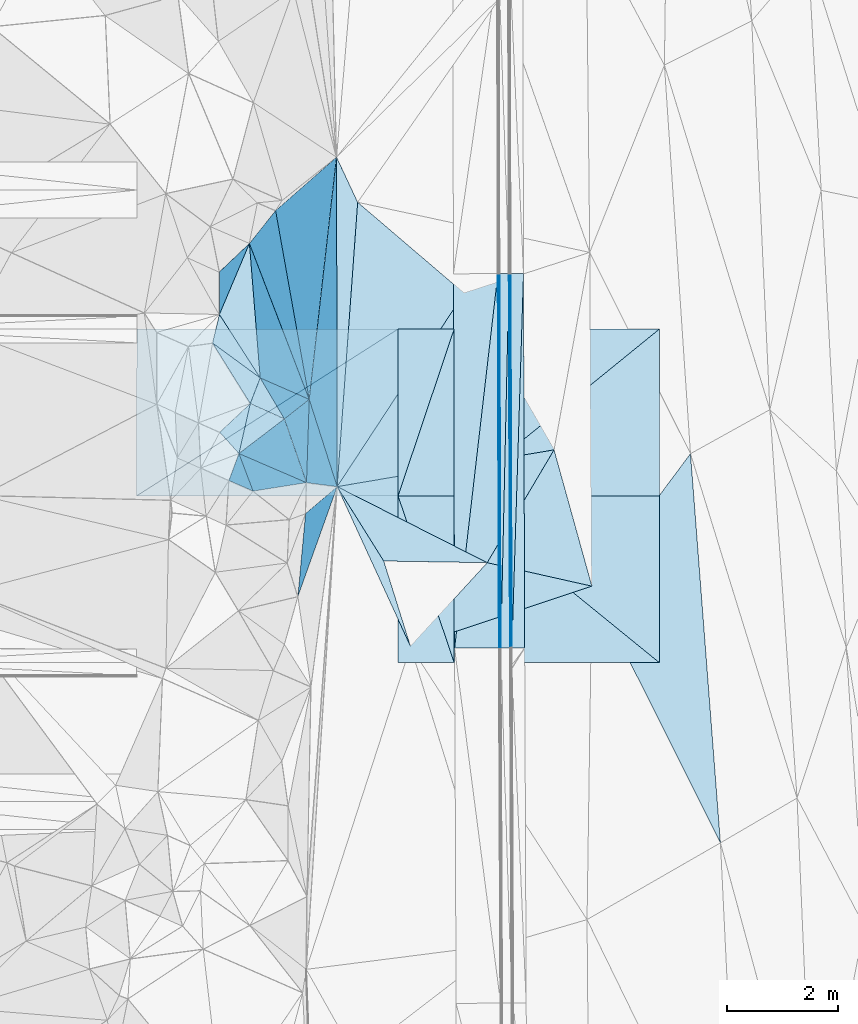
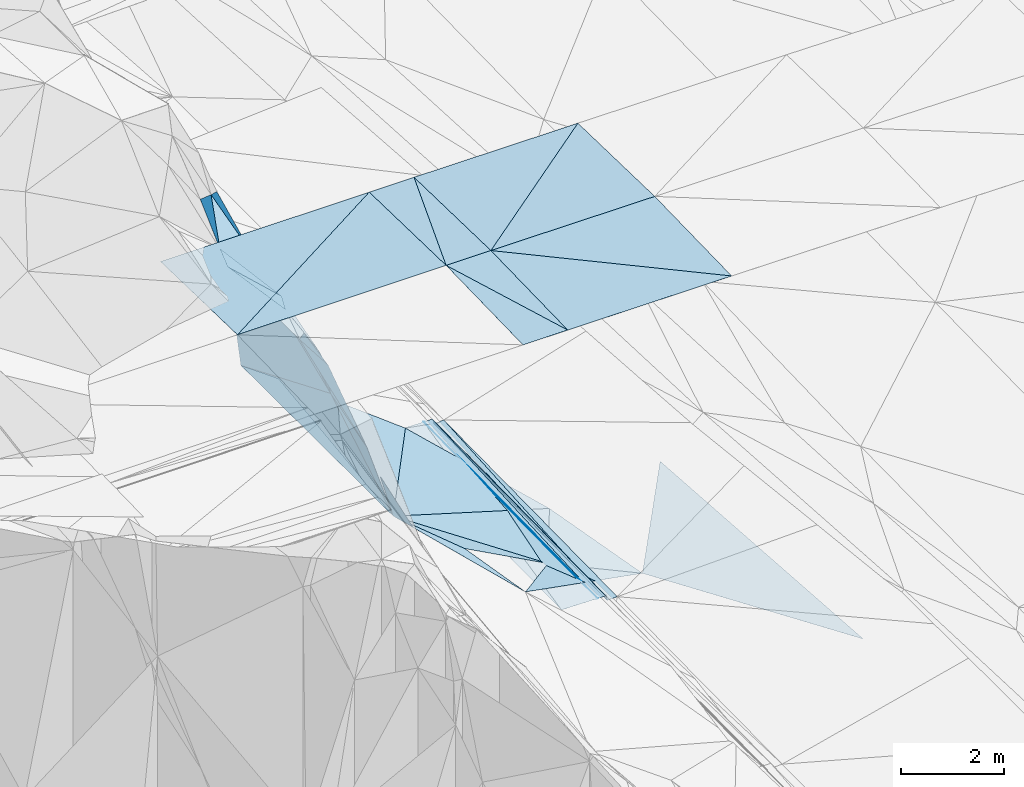
# One storey, part 65 of 275: 47 plates.
"""IFC2X3 building model written with IfcOpenShell, lengths in millimetres."""

from ifc_helpers import new_model, si_unit, frame, origin_with_axes, place, context, subcontext, project, spatial, polyline, outline, extrude, material, type_object, element, save


model = new_model("IFC2X3")

# Units and contexts
model_context = context("Model", 3, precision=1e-05, world=origin_with_axes())
body_context = subcontext(model_context, "Body", "Model", "MODEL_VIEW")
ifc_project = project(units=[si_unit("LENGTHUNIT", "METRE", prefix="MILLI"), si_unit("AREAUNIT", "SQUARE_METRE"), si_unit("VOLUMEUNIT", "CUBIC_METRE"), si_unit("MASSUNIT", "GRAM", prefix="KILO"), si_unit("TIMEUNIT", "SECOND"), si_unit("PLANEANGLEUNIT", "RADIAN"), si_unit("SOLIDANGLEUNIT", "STERADIAN"), si_unit("THERMODYNAMICTEMPERATUREUNIT", "DEGREE_CELSIUS"), si_unit("LUMINOUSINTENSITYUNIT", "LUMEN")], contexts=[model_context])

# Site, building, storey
site_placement = place(None, origin_with_axes())
site = spatial("IfcSite", under=ifc_project, at=site_placement, CompositionType="ELEMENT")
building_placement = place(site_placement, origin_with_axes())
building = spatial("IfcBuilding", under=site, at=building_placement, Name="Undefined", CompositionType="ELEMENT")
storey_placement = place(building_placement, origin_with_axes())
storey = spatial("IfcBuildingStorey", under=building, at=storey_placement, Name="Undefined", CompositionType="ELEMENT", Elevation=0.0)

# Plates
ifc_material = material()
plate_type_1 = type_object("IfcPlateType", PredefinedType="NOTDEFINED")
plate_1_placement = place(storey_placement, frame((-94084.5866878203, 60556.9607628833, 42156.7079027058), z_axis=(-0.970225952350505, 0.00174318954264599, -0.242195298624425), x_axis=(-0.24219982005239, -0.0107861419939103, 0.970166432272049)))
element("IfcPlate", 1, at=plate_1_placement, inside=storey, type_object=plate_type_1, material=ifc_material, Name="00_PR", context=body_context, shape_type="SweptSolid", body=[
    extrude(outline(polyline([(0.0, 0.0), (123.690116882324, -3.49245965480804e-10), (186.194259643555, 6733.92724609375), (0.0, 0.0)])), frame((-8.85201319254618e-08, 2.18876761149539e-07, -0.5000001331573), z_axis=(0.0, 0.0, 1.0), x_axis=(1.0, 0.0, 0.0)), (0.0, 0.0, 1.0), 1.0),
])
plate_2_placement = place(storey_placement, frame((-94084.5866508757, 60556.9607676116, 42156.707743543), z_axis=(-0.970146549983046, 0.00175578360788355, -0.242513069297131), x_axis=(-0.00761512513655447, 0.999260159427567, 0.0376980589679076)))
element("IfcPlate", 2, at=plate_2_placement, inside=storey, type_object=plate_type_1, material=ifc_material, Name="00_PR", context=body_context, shape_type="SweptSolid", body=[
    extrude(outline(polyline([(0.0, 0.0), (6736.5009765625, -1.44500518217683e-08), (6732.044921875, 123.612670898438), (0.0, 0.0)])), frame((-8.85201319254618e-08, 2.18876761149539e-07, -0.5000001331573), z_axis=(0.0, 0.0, 1.0), x_axis=(1.0, 0.0, 0.0)), (0.0, 0.0, 1.0), 1.0),
])
plate_type_2 = type_object("IfcPlateType", PredefinedType="NOTDEFINED")
plate_3_placement = place(storey_placement, frame((-94305.4100903076, 67288.0426014799, 42410.2821987187), z_axis=(-0.0200661071040708, 0.0198232530296892, -0.999602115836601), x_axis=(0.00316902509738513, -0.999797135364924, -0.0198908369865247)))
element("IfcPlate", 3, at=plate_3_placement, inside=storey, type_object=plate_type_2, material=ifc_material, Name="00_PR", context=body_context, shape_type="SweptSolid", body=[
    extrude(outline(polyline([(0.0, 0.0), (6734.4072265625, -2.37050699070096e-08), (6734.412109375, 30.0058002471924), (0.0, 0.0)])), frame((-8.85201319254618e-08, 2.18876761149539e-07, -0.5000001331573), z_axis=(0.0, 0.0, 1.0), x_axis=(1.0, 0.0, 0.0)), (0.0, 0.0, 1.0), 1.0),
])
plate_4_placement = place(storey_placement, frame((-94335.4103191696, 67287.9645285141, 42410.8821981604), z_axis=(-0.0200434799292692, 0.0198233340457199, -0.999602568193798), x_axis=(0.999796679103083, 0.00260181411594454, -0.0199957749975811)))
element("IfcPlate", 4, at=plate_4_placement, inside=storey, type_object=plate_type_2, material=ifc_material, Name="00_PR", context=body_context, shape_type="SweptSolid", body=[
    extrude(outline(polyline([(0.0, 0.0), (30.0063400268555, 1.74622982740402e-10), (6.49809312820435, 6734.43798828125), (0.0, 0.0)])), frame((-8.85201319254618e-08, 2.18876761149539e-07, -0.5000001331573), z_axis=(0.0, 0.0, 1.0), x_axis=(1.0, 0.0, 0.0)), (0.0, 0.0, 1.0), 1.0),
])
plate_type_3 = type_object("IfcPlateType", PredefinedType="NOTDEFINED")
plate_5_placement = place(storey_placement, frame((-94335.4103191696, 67287.9645285141, 42410.8821981604), z_axis=(-0.0200438489268116, 0.0198206888100903, -0.999602613249532), x_axis=(-0.114812645896332, -0.99323490015568, -0.0173922239814446)))
element("IfcPlate", 5, at=plate_5_placement, inside=storey, type_object=plate_type_3, material=ifc_material, Name="00_PR", context=body_context, shape_type="SweptSolid", body=[
    extrude(outline(polyline([(0.0, 0.0), (6781.9384765625, 2.69792508333921e-08), (93.6457214355469, 794.661682128906), (0.0, 0.0)])), frame((-8.85201319254618e-08, 2.18876761149539e-07, -0.5000001331573), z_axis=(0.0, 0.0, 1.0), x_axis=(1.0, 0.0, 0.0)), (0.0, 0.0, 1.0), 1.0),
])
plate_6_placement = place(storey_placement, frame((-95114.0626632694, 60551.9062880618, 42292.9291988022), z_axis=(-0.0200661071040708, 0.0198232530296892, -0.999602115836601), x_axis=(0.114812645896035, 0.993234900155656, 0.0173922239847419)))
element("IfcPlate", 6, at=plate_6_placement, inside=storey, type_object=plate_type_3, material=ifc_material, Name="00_PR", context=body_context, shape_type="SweptSolid", body=[
    extrude(outline(polyline([(0.0, 0.0), (6781.9384765625, 2.69792508333921e-08), (94.5344314575195, 794.556030273438), (0.0, 0.0)])), frame((-8.85201319254618e-08, 2.18876761149539e-07, -0.5000001331573), z_axis=(0.0, 0.0, 1.0), x_axis=(1.0, 0.0, 0.0)), (0.0, 0.0, 1.0), 1.0),
])
plate_type_4 = type_object("IfcPlateType", PredefinedType="NOTDEFINED")
for number, where, z_axis, x_axis, name in (
    (7, (-95122.3312038768, 60292.3543277602, 49117.0561508997), (0.000281023931239556, 0.0249921740341034, -0.999687607336712), (-0.999999959261864, 5.7025981593102e-05, -0.000279686088416769), "00_PR"),
    (8, (-96130.434008878, 63292.4118475478, 49191.7741507655), (0.000281023931239556, 0.0249921740341034, -0.999687607336712), (0.999999959261864, -5.70259785334166e-05, 0.000279686088395133), "00_PR"),
):
    element("IfcPlate", number, at=place(storey_placement, frame(where, z_axis=z_axis, x_axis=x_axis)), inside=storey, type_object=plate_type_4, material=ifc_material, Name=name, context=body_context, shape_type="SweptSolid", body=[
        extrude(outline(polyline([(0.0, 0.0), (1008.27471923828, -2.35013430938125e-09), (1008.2529296875, 3000.9375), (0.0, 0.0)])), frame((-8.85201319254618e-08, 2.18876761149539e-07, -0.5000001331573), z_axis=(0.0, 0.0, 1.0), x_axis=(1.0, 0.0, 0.0)), (0.0, 0.0, 1.0), 1.0),
    ])
for number, where, z_axis, x_axis, name in (
    (9, (-95121.9874384539, 66292.3293787382, 49117.0561508634), (0.000278173513506451, -0.0249922059940395, -0.999687607334935), (-5.7277968073799e-05, -0.999687644772795, 0.0249921909375039), "00_PR"),
    (10, (-96130.4340091923, 63292.3868551628, 49191.7741506891), (0.000278173513506451, -0.0249922059940395, -0.999687607334935), (5.72779774420735e-05, 0.999687644773175, -0.0249921909222736), "00_PR"),
):
    element("IfcPlate", number, at=place(storey_placement, frame(where, z_axis=z_axis, x_axis=x_axis)), inside=storey, type_object=plate_type_4, material=ifc_material, Name=name, context=body_context, shape_type="SweptSolid", body=[
        extrude(outline(polyline([(0.0, 0.0), (3000.9375, -1.02954800240695e-08), (3000.9306640625, 1008.27471923828), (0.0, 0.0)])), frame((-8.85201319254618e-08, 2.18876761149539e-07, -0.5000001331573), z_axis=(0.0, 0.0, 1.0), x_axis=(1.0, 0.0, 0.0)), (0.0, 0.0, 1.0), 1.0),
    ])
plate_type_5 = type_object("IfcPlateType", PredefinedType="NOTDEFINED")
plate_7_placement = place(storey_placement, frame((-93875.3859893209, 67289.165397345, 42297.7823657598), z_axis=(0.032610820137696, 0.0199851061391093, -0.99926829727684), x_axis=(0.00316918013075106, -0.99979710662253, -0.0198922569487769)))
element("IfcPlate", 11, at=plate_7_placement, inside=storey, type_object=plate_type_5, material=ifc_material, Name="00_PR", context=body_context, shape_type="SweptSolid", body=[
    extrude(outline(polyline([(0.0, 0.0), (6733.9267578125, -4.21860022470355e-08), (6732.98193359375, 230.160888671875), (0.0, 0.0)])), frame((-8.85201319254618e-08, 2.18876761149539e-07, -0.5000001331573), z_axis=(0.0, 0.0, 1.0), x_axis=(1.0, 0.0, 0.0)), (0.0, 0.0, 1.0), 1.0),
])
plate_8_placement = place(storey_placement, frame((-94105.3869777647, 67288.7833583574, 42290.2823658432), z_axis=(0.0325515627490453, 0.0199869826689381, -0.999270191833213), x_axis=(0.999467387218962, 0.00166014710374313, 0.0325911920201744)))
element("IfcPlate", 12, at=plate_8_placement, inside=storey, type_object=plate_type_5, material=ifc_material, Name="00_PR", context=body_context, shape_type="SweptSolid", body=[
    extrude(outline(polyline([(0.0, 0.0), (230.123519897461, -3.34694050252438e-10), (5.74884033203125, 6733.17724609375), (0.0, 0.0)])), frame((-8.85201319254618e-08, 2.18876761149539e-07, -0.5000001331573), z_axis=(0.0, 0.0, 1.0), x_axis=(1.0, 0.0, 0.0)), (0.0, 0.0, 1.0), 1.0),
])
plate_type_6 = type_object("IfcPlateType", PredefinedType="NOTDEFINED")
plate_9_placement = place(storey_placement, frame((-97729.0129471622, 65026.976382689, 45649.8515292307), z_axis=(-0.949413778451804, 0.1022107257101, -0.29692834966652), x_axis=(0.185652976281151, -0.579917402025729, -0.793239421124341)))
element("IfcPlate", 13, at=plate_9_placement, inside=storey, type_object=plate_type_6, material=ifc_material, Name="00", context=body_context, shape_type="SweptSolid", body=[
    extrude(outline(polyline([(0.0, 0.0), (2705.3623046875, 1.89538695849478e-09), (1144.98901367188, 1031.30993652344), (0.0, 0.0)])), frame((-8.85201319254618e-08, 2.18876761149539e-07, -0.5000001331573), z_axis=(0.0, 0.0, 1.0), x_axis=(1.0, 0.0, 0.0)), (0.0, 0.0, 1.0), 1.0),
])
plate_type_7 = type_object("IfcPlateType", PredefinedType="NOTDEFINED")
plate_10_placement = place(storey_placement, frame((-94135.4009124375, 67288.4866324256, 42410.2820987811), z_axis=(-7.42149505654779e-05, 0.0198912636301427, -0.999802146488663), x_axis=(0.00316902509738513, -0.999797135364924, -0.0198908369865247)))
element("IfcPlate", 14, at=plate_10_placement, inside=storey, type_object=plate_type_7, material=ifc_material, Name="00_PR", context=body_context, shape_type="SweptSolid", body=[
    extrude(outline(polyline([(0.0, 0.0), (6734.21728515625, -2.71975295618176e-08), (6734.3125, 170.000411987305), (0.0, 0.0)])), frame((-8.85201319254618e-08, 2.18876761149539e-07, -0.5000001331573), z_axis=(0.0, 0.0, 1.0), x_axis=(1.0, 0.0, 0.0)), (0.0, 0.0, 1.0), 1.0),
])
plate_11_placement = place(storey_placement, frame((-94284.0585795608, 60555.001422648, 42276.329099369), z_axis=(-5.1949872207255e-05, 0.0198907722185341, -0.999802157670087), x_axis=(-0.00316902511082895, 0.999797135365324, 0.019890836964273)))
element("IfcPlate", 15, at=plate_11_placement, inside=storey, type_object=plate_type_7, material=ifc_material, Name="00_PR", context=body_context, shape_type="SweptSolid", body=[
    extrude(outline(polyline([(0.0, 0.0), (6734.4072265625, -2.37050699070096e-08), (6734.3125, 169.999740600586), (0.0, 0.0)])), frame((-8.85201319254618e-08, 2.18876761149539e-07, -0.5000001331573), z_axis=(0.0, 0.0, 1.0), x_axis=(1.0, 0.0, 0.0)), (0.0, 0.0, 1.0), 1.0),
])
plate_type_8 = type_object("IfcPlateType", PredefinedType="NOTDEFINED")
plate_12_placement = place(storey_placement, frame((-92645.6537894122, 61668.4428405591, 41623.5255508065), z_axis=(-0.31448106914999, 0.0273092371681357, -0.948870835631264), x_axis=(-0.926719768528526, 0.207720038447267, 0.313117958996129)))
element("IfcPlate", 16, at=plate_12_placement, inside=storey, type_object=plate_type_8, material=ifc_material, Name="00", context=body_context, shape_type="SweptSolid", body=[
    extrude(outline(polyline([(0.0, 0.0), (2031.18334960938, -3.20142135024071e-10), (1232.25500488281, 2245.13110351563), (0.0, 0.0)])), frame((-8.85201319254618e-08, 2.18876761149539e-07, -0.5000001331573), z_axis=(0.0, 0.0, 1.0), x_axis=(1.0, 0.0, 0.0)), (0.0, 0.0, 1.0), 1.0),
])
plate_type_9 = type_object("IfcPlateType", PredefinedType="NOTDEFINED")
plate_13_placement = place(storey_placement, frame((-93325.9323630613, 64119.7355086362, 41919.5402587067), z_axis=(-0.386048164800384, 0.0746307154173514, -0.919454768202629), x_axis=(-0.504436713180272, -0.851579442888095, 0.142674646823762)))
element("IfcPlate", 17, at=plate_13_placement, inside=storey, type_object=plate_type_9, material=ifc_material, Name="00", context=body_context, shape_type="SweptSolid", body=[
    extrude(outline(polyline([(0.0, 0.0), (2383.04418945313, -7.5087882578373e-09), (2757.02807617188, 3249.59399414063), (0.0, 0.0)])), frame((-8.85201319254618e-08, 2.18876761149539e-07, -0.5000001331573), z_axis=(0.0, 0.0, 1.0), x_axis=(1.0, 0.0, 0.0)), (0.0, 0.0, 1.0), 1.0),
])
plate_type_10 = type_object("IfcPlateType", PredefinedType="NOTDEFINED")
plate_14_placement = place(storey_placement, frame((-97794.9709282415, 62975.1054887549, 44939.8381126142), z_axis=(-0.9359444355159, 0.138510399964921, -0.323763621687769), x_axis=(0.351165805890991, 0.29849872396992, -0.887457654517251)))
element("IfcPlate", 18, at=plate_14_placement, inside=storey, type_object=plate_type_10, material=ifc_material, Name="00", context=body_context, shape_type="SweptSolid", body=[
    extrude(outline(polyline([(0.0, 0.0), (1618.10534667969, -2.29920260608196e-09), (-281.211608886719, 1492.48791503906), (0.0, 0.0)])), frame((-8.85201319254618e-08, 2.18876761149539e-07, -0.5000001331573), z_axis=(0.0, 0.0, 1.0), x_axis=(1.0, 0.0, 0.0)), (0.0, 0.0, 1.0), 1.0),
])
plate_type_11 = type_object("IfcPlateType", PredefinedType="NOTDEFINED")
plate_15_placement = place(storey_placement, frame((-98804.5290154926, 67831.573198819, 49059.5566099958), z_axis=(-0.302121600908731, 0.349809043911841, -0.886767258677173), x_axis=(0.0738229933103027, -0.918858558215451, -0.387619808127667)))
element("IfcPlate", 19, at=plate_15_placement, inside=storey, type_object=plate_type_11, material=ifc_material, Name="00", context=body_context, shape_type="SweptSolid", body=[
    extrude(outline(polyline([(0.0, 0.0), (2631.44458007813, -7.7707227319479e-09), (1257.82629394531, 665.487060546875), (0.0, 0.0)])), frame((-8.85201319254618e-08, 2.18876761149539e-07, -0.5000001331573), z_axis=(0.0, 0.0, 1.0), x_axis=(1.0, 0.0, 0.0)), (0.0, 0.0, 1.0), 1.0),
])
plate_type_12 = type_object("IfcPlateType", PredefinedType="NOTDEFINED")
plate_16_placement = place(storey_placement, frame((-91430.6064080137, 60292.1428072807, 49113.2711514033), z_axis=(-0.00102351271572016, 0.0249922368443512, -0.999687121313082), x_axis=(-0.999999472774374, 5.7295979518523e-05, 0.00102526491432853)))
element("IfcPlate", 20, at=plate_16_placement, inside=storey, type_object=plate_type_12, material=ifc_material, Name="00_PR", context=body_context, shape_type="SweptSolid", body=[
    extrude(outline(polyline([(0.0, 0.0), (3691.72729492188, 1.56433088704944e-09), (3691.80419921875, 3000.9375), (0.0, 0.0)])), frame((-8.85201319254618e-08, 2.18876761149539e-07, -0.5000001331573), z_axis=(0.0, 0.0, 1.0), x_axis=(1.0, 0.0, 0.0)), (0.0, 0.0, 1.0), 1.0),
])
for number, where, z_axis, x_axis, name in (
    (21, (-91430.2626426598, 66292.1178582667, 49113.271151401), (-0.00102637697242818, -0.0249921190947354, -0.999687121320198), (-5.7277968073799e-05, -0.999687644772795, 0.0249921909375039), "00_PR"),
    (22, (-95122.1599724902, 63292.3293568809, 49192.0561511152), (-0.00102637697242818, -0.0249921190947354, -0.999687121320198), (5.72779774420735e-05, 0.999687644773175, -0.0249921909222736), "00_PR"),
):
    element("IfcPlate", number, at=place(storey_placement, frame(where, z_axis=z_axis, x_axis=x_axis)), inside=storey, type_object=plate_type_12, material=ifc_material, Name=name, context=body_context, shape_type="SweptSolid", body=[
        extrude(outline(polyline([(0.0, 0.0), (3000.9375, -1.02954800240695e-08), (3001.03198242188, 3691.72729492188), (0.0, 0.0)])), frame((-8.85201319254618e-08, 2.18876761149539e-07, -0.5000001331573), z_axis=(0.0, 0.0, 1.0), x_axis=(1.0, 0.0, 0.0)), (0.0, 0.0, 1.0), 1.0),
    ])
plate_17_placement = place(storey_placement, frame((-96130.2613341139, 66292.3868764003, 49116.7741514976), z_axis=(0.001863302635371, -0.024992254340801, -0.99968590833634), x_axis=(-5.7277968073799e-05, -0.999687644772795, 0.0249921909375039)))
element("IfcPlate", 23, at=plate_17_placement, inside=storey, type_object=plate_type_12, material=ifc_material, Name="00_PR", context=body_context, shape_type="SweptSolid", body=[
    extrude(outline(polyline([(0.0, 0.0), (3000.9375, -1.02954800240695e-08), (3000.71850585938, 4700.00830078125), (0.0, 0.0)])), frame((-8.85201319254618e-08, 2.18876761149539e-07, -0.5000001331573), z_axis=(0.0, 0.0, 1.0), x_axis=(1.0, 0.0, 0.0)), (0.0, 0.0, 1.0), 1.0),
])
plate_18_placement = place(storey_placement, frame((-95122.1599711553, 63292.3543493107, 49192.0561507792), z_axis=(-0.00102351271572016, 0.0249922368443512, -0.999687121313082), x_axis=(0.999999472774367, -5.72959640037441e-05, -0.00102526492224361)))
element("IfcPlate", 24, at=plate_18_placement, inside=storey, type_object=plate_type_12, material=ifc_material, Name="00_PR", context=body_context, shape_type="SweptSolid", body=[
    extrude(outline(polyline([(0.0, 0.0), (3691.72729492188, 1.56433088704944e-09), (3691.80419921875, 3000.9375), (0.0, 0.0)])), frame((-8.85201319254618e-08, 2.18876761149539e-07, -0.5000001331573), z_axis=(0.0, 0.0, 1.0), x_axis=(1.0, 0.0, 0.0)), (0.0, 0.0, 1.0), 1.0),
])
plate_19_placement = place(storey_placement, frame((-100830.433351927, 63292.6558727185, 49183.0071509998), z_axis=(0.00186372776540694, -0.0249929203530909, -0.999685890893255), x_axis=(5.72779774420735e-05, 0.999687644773175, -0.0249921909222736)))
element("IfcPlate", 25, at=plate_19_placement, inside=storey, type_object=plate_type_12, material=ifc_material, Name="00_PR", context=body_context, shape_type="SweptSolid", body=[
    extrude(outline(polyline([(0.0, 0.0), (3000.9375, -1.02954800240695e-08), (3000.71850585938, 4700.00830078125), (0.0, 0.0)])), frame((-8.85201319254618e-08, 2.18876761149539e-07, -0.5000001331573), z_axis=(0.0, 0.0, 1.0), x_axis=(1.0, 0.0, 0.0)), (0.0, 0.0, 1.0), 1.0),
])
plate_type_13 = type_object("IfcPlateType", PredefinedType="NOTDEFINED")
plate_20_placement = place(storey_placement, frame((-99344.3856564315, 66554.3548570397, 48739.762612208), z_axis=(-0.761778840726677, 0.440786445360276, -0.474763422567253), x_axis=(0.000467091726900332, 0.733217266604419, 0.679994280695406)))
element("IfcPlate", 26, at=plate_20_placement, inside=storey, type_object=plate_type_13, material=ifc_material, Name="00", context=body_context, shape_type="SweptSolid", body=[
    extrude(outline(polyline([(0.0, 0.0), (1044.12646484375, 3.88536136597395e-09), (1154.36218261719, 832.134643554688), (0.0, 0.0)])), frame((-8.85201319254618e-08, 2.18876761149539e-07, -0.5000001331573), z_axis=(0.0, 0.0, 1.0), x_axis=(1.0, 0.0, 0.0)), (0.0, 0.0, 1.0), 1.0),
])
plate_type_14 = type_object("IfcPlateType", PredefinedType="NOTDEFINED")
plate_21_placement = place(storey_placement, frame((-98175.3707252625, 64676.6801529666, 46999.7787070695), z_axis=(-0.813305025331479, 0.377708118352602, -0.442573737473315), x_axis=(0.189680144208434, -0.546974661792582, -0.815377312812883)))
element("IfcPlate", 27, at=plate_21_placement, inside=storey, type_object=plate_type_14, material=ifc_material, Name="00", context=body_context, shape_type="SweptSolid", body=[
    extrude(outline(polyline([(0.0, 0.0), (2097.1884765625, 7.27595761418343e-11), (-604.762023925781, 1277.79614257813), (0.0, 0.0)])), frame((-8.85201319254618e-08, 2.18876761149539e-07, -0.5000001331573), z_axis=(0.0, 0.0, 1.0), x_axis=(1.0, 0.0, 0.0)), (0.0, 0.0, 1.0), 1.0),
])
plate_type_15 = type_object("IfcPlateType", PredefinedType="NOTDEFINED")
plate_22_placement = place(storey_placement, frame((-98610.3403071143, 65413.593583375, 48039.5692604605), z_axis=(-0.446920063968735, 0.241120485339661, -0.861465825190848), x_axis=(-0.696811283386019, 0.510069385966262, 0.504265066057456)))
element("IfcPlate", 28, at=plate_22_placement, inside=storey, type_object=plate_type_15, material=ifc_material, Name="00", context=body_context, shape_type="SweptSolid", body=[
    extrude(outline(polyline([(0.0, 0.0), (1229.51208496094, -5.42604539077729e-09), (1446.18347167969, 488.112213134766), (0.0, 0.0)])), frame((-8.85201319254618e-08, 2.18876761149539e-07, -0.5000001331573), z_axis=(0.0, 0.0, 1.0), x_axis=(1.0, 0.0, 0.0)), (0.0, 0.0, 1.0), 1.0),
])
plate_type_16 = type_object("IfcPlateType", PredefinedType="NOTDEFINED")
plate_23_placement = place(storey_placement, frame((-98992.8733392252, 64052.7545565147, 47969.6556119816), z_axis=(-0.689139973139033, 0.225143976380605, -0.68876431914078), x_axis=(-0.493809782021908, 0.549714109643534, 0.673770210708586)))
element("IfcPlate", 29, at=plate_23_placement, inside=storey, type_object=plate_type_16, material=ifc_material, Name="00", context=body_context, shape_type="SweptSolid", body=[
    extrude(outline(polyline([(0.0, 0.0), (697.567199707031, -1.7134880181402e-09), (454.293151855469, 807.352294921875), (0.0, 0.0)])), frame((-8.85201319254618e-08, 2.18876761149539e-07, -0.5000001331573), z_axis=(0.0, 0.0, 1.0), x_axis=(1.0, 0.0, 0.0)), (0.0, 0.0, 1.0), 1.0),
])
plate_type_17 = type_object("IfcPlateType", PredefinedType="NOTDEFINED")
plate_24_placement = place(storey_placement, frame((-98333.6004151888, 68422.4248126637, 48609.8957538357), z_axis=(-0.977997037503317, 0.0076071755901162, -0.208480036248741), x_axis=(0.206388429077881, 0.18101859505543, -0.961579993857465)))
element("IfcPlate", 30, at=plate_24_placement, inside=storey, type_object=plate_type_17, material=ifc_material, Name="00", context=body_context, shape_type="SweptSolid", body=[
    extrude(outline(polyline([(0.0, 0.0), (5310.0107421875, -8.43283487483859e-09), (2356.40576171875, 3886.36743164063), (0.0, 0.0)])), frame((-8.85201319254618e-08, 2.18876761149539e-07, -0.5000001331573), z_axis=(0.0, 0.0, 1.0), x_axis=(1.0, 0.0, 0.0)), (0.0, 0.0, 1.0), 1.0),
])
plate_type_18 = type_object("IfcPlateType", PredefinedType="NOTDEFINED")
plate_25_placement = place(storey_placement, frame((-98804.8437255249, 67831.4359163764, 49059.8221052886), z_axis=(-0.931536887466923, 0.07524283018599, -0.355777379542376), x_axis=(0.2367452281491, -0.617141751608491, -0.750391734609487)))
element("IfcPlate", 31, at=plate_25_placement, inside=storey, type_object=plate_type_18, material=ifc_material, Name="00", context=body_context, shape_type="SweptSolid", body=[
    extrude(outline(polyline([(0.0, 0.0), (4544.29296875, 2.24972609430552e-08), (2303.59252929688, 1271.99096679688), (0.0, 0.0)])), frame((-8.85201319254618e-08, 2.18876761149539e-07, -0.5000001331573), z_axis=(0.0, 0.0, 1.0), x_axis=(1.0, 0.0, 0.0)), (0.0, 0.0, 1.0), 1.0),
])
plate_type_19 = type_object("IfcPlateType", PredefinedType="NOTDEFINED")
plate_26_placement = place(storey_placement, frame((-97728.9500601108, 65027.0663713673, 45649.7540277033), z_axis=(-0.823632692317256, 0.282190049867413, -0.491932885566777), x_axis=(-0.236745228145541, 0.617141751608518, 0.750391734610587)))
element("IfcPlate", 32, at=plate_26_placement, inside=storey, type_object=plate_type_19, material=ifc_material, Name="00", context=body_context, shape_type="SweptSolid", body=[
    extrude(outline(polyline([(0.0, 0.0), (4544.29296875, 2.24972609430552e-08), (4459.79150390625, 875.648010253906), (0.0, 0.0)])), frame((-8.85201319254618e-08, 2.18876761149539e-07, -0.5000001331573), z_axis=(0.0, 0.0, 1.0), x_axis=(1.0, 0.0, 0.0)), (0.0, 0.0, 1.0), 1.0),
])
plate_type_20 = type_object("IfcPlateType", PredefinedType="NOTDEFINED")
plate_27_placement = place(storey_placement, frame((-97729.0078369464, 65026.8827284528, 45649.8336594366), z_axis=(-0.939195944609047, -0.0851007208299358, -0.332669272617935), x_axis=(-0.304842959119448, -0.239294689155973, 0.921850759080365)))
element("IfcPlate", 33, at=plate_27_placement, inside=storey, type_object=plate_type_20, material=ifc_material, Name="00", context=body_context, shape_type="SweptSolid", body=[
    extrude(outline(polyline([(0.0, 0.0), (1464.4453125, -1.30967237055302e-09), (2379.46752929688, 988.349304199219), (0.0, 0.0)])), frame((-8.85201319254618e-08, 2.18876761149539e-07, -0.5000001331573), z_axis=(0.0, 0.0, 1.0), x_axis=(1.0, 0.0, 0.0)), (0.0, 0.0, 1.0), 1.0),
])
plate_type_21 = type_object("IfcPlateType", PredefinedType="NOTDEFINED")
plate_28_placement = place(storey_placement, frame((-99467.1052581036, 66040.6879822903, 48659.5744505028), z_axis=(-0.501017001605788, 0.156956015699322, -0.851085643891224), x_axis=(0.696811283384014, -0.510069385968338, -0.504265066058125)))
element("IfcPlate", 34, at=plate_28_placement, inside=storey, type_object=plate_type_21, material=ifc_material, Name="00", context=body_context, shape_type="SweptSolid", body=[
    extrude(outline(polyline([(0.0, 0.0), (1229.51208496094, -5.42604539077729e-09), (1330.44641113281, 484.986877441406), (0.0, 0.0)])), frame((-8.85201319254618e-08, 2.18876761149539e-07, -0.5000001331573), z_axis=(0.0, 0.0, 1.0), x_axis=(1.0, 0.0, 0.0)), (0.0, 0.0, 1.0), 1.0),
])
plate_type_22 = type_object("IfcPlateType", PredefinedType="NOTDEFINED")
plate_29_placement = place(storey_placement, frame((-97237.6736514674, 69383.6307778143, 43503.8866722173), z_axis=(-0.973976312382801, -0.00179275567526314, -0.22664273415287), x_axis=(0.00184065323047436, -0.999998305996408, -3.29343245081389e-11)))
element("IfcPlate", 35, at=plate_29_placement, inside=storey, type_object=plate_type_22, material=ifc_material, Name="00", context=body_context, shape_type="SweptSolid", body=[
    extrude(outline(polyline([(0.0, 0.0), (5925.60302734375, -1.77751644514501e-08), (4355.79443359375, 2203.33520507813), (0.0, 0.0)])), frame((-8.85201319254618e-08, 2.18876761149539e-07, -0.5000001331573), z_axis=(0.0, 0.0, 1.0), x_axis=(1.0, 0.0, 0.0)), (0.0, 0.0, 1.0), 1.0),
])
plate_type_23 = type_object("IfcPlateType", PredefinedType="NOTDEFINED")
plate_30_placement = place(storey_placement, frame((-98175.3619160035, 64676.6336292953, 46999.732667911), z_axis=(-0.795685255165916, 0.284663943605202, -0.534650740131056), x_axis=(-0.488873050133581, 0.219326727846412, 0.844333421880998)))
element("IfcPlate", 36, at=plate_30_placement, inside=storey, type_object=plate_type_23, material=ifc_material, Name="00", context=body_context, shape_type="SweptSolid", body=[
    extrude(outline(polyline([(0.0, 0.0), (1255.42822265625, 5.16229192726314e-09), (1252.48095703125, 495.369873046875), (0.0, 0.0)])), frame((-8.85201319254618e-08, 2.18876761149539e-07, -0.5000001331573), z_axis=(0.0, 0.0, 1.0), x_axis=(1.0, 0.0, 0.0)), (0.0, 0.0, 1.0), 1.0),
])
plate_type_24 = type_object("IfcPlateType", PredefinedType="NOTDEFINED")
plate_31_placement = place(storey_placement, frame((-98789.1154088106, 64951.9589931608, 48059.7338926508), z_axis=(-0.812631897917396, 0.237465532042007, -0.532202517449116), x_axis=(0.488873050140592, -0.219326727830008, -0.8443334218812)))
element("IfcPlate", 37, at=plate_31_placement, inside=storey, type_object=plate_type_24, material=ifc_material, Name="00", context=body_context, shape_type="SweptSolid", body=[
    extrude(outline(polyline([(0.0, 0.0), (1255.42822265625, 5.16229192726314e-09), (173.566268920898, 909.986145019531), (0.0, 0.0)])), frame((-8.85201319254618e-08, 2.18876761149539e-07, -0.5000001331573), z_axis=(0.0, 0.0, 1.0), x_axis=(1.0, 0.0, 0.0)), (0.0, 0.0, 1.0), 1.0),
])
plate_type_25 = type_object("IfcPlateType", PredefinedType="NOTDEFINED")
plate_32_placement = place(storey_placement, frame((-98738.4399230249, 63377.860663021, 47679.8116467881), z_axis=(-0.908513243385723, -0.180844792770516, -0.376694634313448), x_axis=(-0.327496690351513, 0.868061378190685, 0.373115748129844)))
element("IfcPlate", 38, at=plate_32_placement, inside=storey, type_object=plate_type_25, material=ifc_material, Name="00", context=body_context, shape_type="SweptSolid", body=[
    extrude(outline(polyline([(0.0, 0.0), (777.238708496094, 2.08819983527064e-09), (-1074.95935058594, 2345.775390625), (0.0, 0.0)])), frame((-8.85201319254618e-08, 2.18876761149539e-07, -0.5000001331573), z_axis=(0.0, 0.0, 1.0), x_axis=(1.0, 0.0, 0.0)), (0.0, 0.0, 1.0), 1.0),
])
plate_type_26 = type_object("IfcPlateType", PredefinedType="NOTDEFINED")
plate_33_placement = place(storey_placement, frame((-97777.6450945762, 63529.4324483508, 45289.855592624), z_axis=(-0.952115266069773, 0.10034524443068, -0.288803310294451), x_axis=(-0.189680144183299, 0.546974661788651, 0.815377312821367)))
element("IfcPlate", 39, at=plate_33_placement, inside=storey, type_object=plate_type_26, material=ifc_material, Name="00", context=body_context, shape_type="SweptSolid", body=[
    extrude(outline(polyline([(0.0, 0.0), (2097.1884765625, 7.27595761418343e-11), (1103.42956542969, 1075.65942382813), (0.0, 0.0)])), frame((-8.85201319254618e-08, 2.18876761149539e-07, -0.5000001331573), z_axis=(0.0, 0.0, 1.0), x_axis=(1.0, 0.0, 0.0)), (0.0, 0.0, 1.0), 1.0),
])
plate_type_27 = type_object("IfcPlateType", PredefinedType="NOTDEFINED")
plate_34_placement = place(storey_placement, frame((-98738.4275625141, 63377.8801926893, 47679.7770582332), z_axis=(-0.883795801569295, -0.141785250489854, -0.445872093623291), x_axis=(-0.466875859961628, 0.205078016770508, 0.860215053589837)))
element("IfcPlate", 40, at=plate_34_placement, inside=storey, type_object=plate_type_27, material=ifc_material, Name="00", context=body_context, shape_type="SweptSolid", body=[
    extrude(outline(polyline([(0.0, 0.0), (930.0, 3.17231751978397e-09), (506.666656494141, 589.397033691406), (0.0, 0.0)])), frame((-8.85201319254618e-08, 2.18876761149539e-07, -0.5000001331573), z_axis=(0.0, 0.0, 1.0), x_axis=(1.0, 0.0, 0.0)), (0.0, 0.0, 1.0), 1.0),
])
plate_type_28 = type_object("IfcPlateType", PredefinedType="NOTDEFINED")
plate_35_placement = place(storey_placement, frame((-97226.219431648, 63458.0387691307, 43503.5036403524), z_axis=(0.120746784632075, 0.000222253390577919, -0.9926833153652), x_axis=(-0.00184065355970219, 0.999998305995802, 1.5235593859406e-11)))
element("IfcPlate", 41, at=plate_35_placement, inside=storey, type_object=plate_type_28, material=ifc_material, Name="00", context=body_context, shape_type="SweptSolid", body=[
    extrude(outline(polyline([(0.0, 0.0), (5925.60302734375, -1.77751644514501e-08), (5113.10009765625, 380.961883544922), (0.0, 0.0)])), frame((-8.85201319254618e-08, 2.18876761149539e-07, -0.5000001331573), z_axis=(0.0, 0.0, 1.0), x_axis=(1.0, 0.0, 0.0)), (0.0, 0.0, 1.0), 1.0),
])
plate_type_29 = type_object("IfcPlateType", PredefinedType="NOTDEFINED")
plate_36_placement = place(storey_placement, frame((-96389.1421914485, 62120.3363395887, 43249.5625260808), z_axis=(-0.467456587508301, -0.126495492048485, -0.874918984413132), x_axis=(-0.52387044652441, 0.836844505553906, 0.158905722938331)))
element("IfcPlate", 42, at=plate_36_placement, inside=storey, type_object=plate_type_29, material=ifc_material, Name="00", context=body_context, shape_type="SweptSolid", body=[
    extrude(outline(polyline([(0.0, 0.0), (1598.43200683594, 9.51695255935192e-09), (-1157.42797851563, 1762.08984375), (0.0, 0.0)])), frame((-8.85201319254618e-08, 2.18876761149539e-07, -0.5000001331573), z_axis=(0.0, 0.0, 1.0), x_axis=(1.0, 0.0, 0.0)), (0.0, 0.0, 1.0), 1.0),
])
plate_type_30 = type_object("IfcPlateType", PredefinedType="NOTDEFINED")
plate_37_placement = place(storey_placement, frame((-94528.006083948, 62090.2815657964, 42259.5349366155), z_axis=(-0.343449725110675, -0.130229130514045, -0.930098199055862), x_axis=(0.926719768526968, -0.207720038448812, -0.313117958999715)))
element("IfcPlate", 43, at=plate_37_placement, inside=storey, type_object=plate_type_30, material=ifc_material, Name="00", context=body_context, shape_type="SweptSolid", body=[
    extrude(outline(polyline([(0.0, 0.0), (2031.18334960938, -3.20142135024071e-10), (-1190.31591796875, 1808.54858398438), (0.0, 0.0)])), frame((-8.85201319254618e-08, 2.18876761149539e-07, -0.5000001331573), z_axis=(0.0, 0.0, 1.0), x_axis=(1.0, 0.0, 0.0)), (0.0, 0.0, 1.0), 1.0),
])
plate_type_31 = type_object("IfcPlateType", PredefinedType="NOTDEFINED")
plate_38_placement = place(storey_placement, frame((-90333.3407168096, 57052.0998556235, 42047.5186278292), z_axis=(0.266722157472511, 0.0451604529838193, -0.962714819767259), x_axis=(-0.446307041501333, 0.891129028791487, -0.0818479001042117)))
element("IfcPlate", 44, at=plate_38_placement, inside=storey, type_object=plate_type_31, material=ifc_material, Name="00", context=body_context, shape_type="SweptSolid", body=[
    extrude(outline(polyline([(0.0, 0.0), (5180.3408203125, 1.9317667465657e-08), (6462.646484375, 2745.71826171875), (0.0, 0.0)])), frame((-8.85201319254618e-08, 2.18876761149539e-07, -0.5000001331573), z_axis=(0.0, 0.0, 1.0), x_axis=(1.0, 0.0, 0.0)), (0.0, 0.0, 1.0), 1.0),
])
plate_type_32 = type_object("IfcPlateType", PredefinedType="NOTDEFINED")
plate_39_placement = place(storey_placement, frame((-93325.9298570979, 64119.7151303482, 41919.5379995476), z_axis=(-0.380968065243029, 0.0338803194276686, -0.923967238174851), x_axis=(-0.915280326849906, -0.155261549499301, 0.371693118753367)))
element("IfcPlate", 45, at=plate_39_placement, inside=storey, type_object=plate_type_32, material=ifc_material, Name="00", context=body_context, shape_type="SweptSolid", body=[
    extrude(outline(polyline([(0.0, 0.0), (4261.580078125, 2.79542291536927e-08), (1328.88269042969, 3061.93896484375), (0.0, 0.0)])), frame((-8.85201319254618e-08, 2.18876761149539e-07, -0.5000001331573), z_axis=(0.0, 0.0, 1.0), x_axis=(1.0, 0.0, 0.0)), (0.0, 0.0, 1.0), 1.0),
])
plate_type_33 = type_object("IfcPlateType", PredefinedType="NOTDEFINED")
plate_40_placement = place(storey_placement, frame((-94942.9274447997, 66936.4204805673, 42689.5386112209), z_axis=(-0.383718312983511, 0.0359708645272522, -0.922749344722743), x_axis=(-0.538592937410089, -0.820401116226281, 0.191988687861145)))
element("IfcPlate", 46, at=plate_40_placement, inside=storey, type_object=plate_type_33, material=ifc_material, Name="00", context=body_context, shape_type="SweptSolid", body=[
    extrude(outline(polyline([(0.0, 0.0), (4239.8330078125, 1.94995664060116e-09), (-145.305252075195, 2656.96948242188), (0.0, 0.0)])), frame((-8.85201319254618e-08, 2.18876761149539e-07, -0.5000001331573), z_axis=(0.0, 0.0, 1.0), x_axis=(1.0, 0.0, 0.0)), (0.0, 0.0, 1.0), 1.0),
])
plate_type_34 = type_object("IfcPlateType", PredefinedType="NOTDEFINED")
plate_41_placement = place(storey_placement, frame((-95906.6103187366, 60584.3259471027, 42979.5068771243), z_axis=(-0.0446384415596493, 0.159325501119649, -0.986216403345685), x_axis=(-0.411703794498707, 0.896536032452623, 0.163472101930192)))
element("IfcPlate", 47, at=plate_41_placement, inside=storey, type_object=plate_type_34, material=ifc_material, Name="00", context=body_context, shape_type="SweptSolid", body=[
    extrude(outline(polyline([(0.0, 0.0), (3205.43994140625, 6.6720531322062e-09), (1619.92736816406, 202.818023681641), (0.0, 0.0)])), frame((-8.85201319254618e-08, 2.18876761149539e-07, -0.5000001331573), z_axis=(0.0, 0.0, 1.0), x_axis=(1.0, 0.0, 0.0)), (0.0, 0.0, 1.0), 1.0),
])

save(model, "model.ifc")
